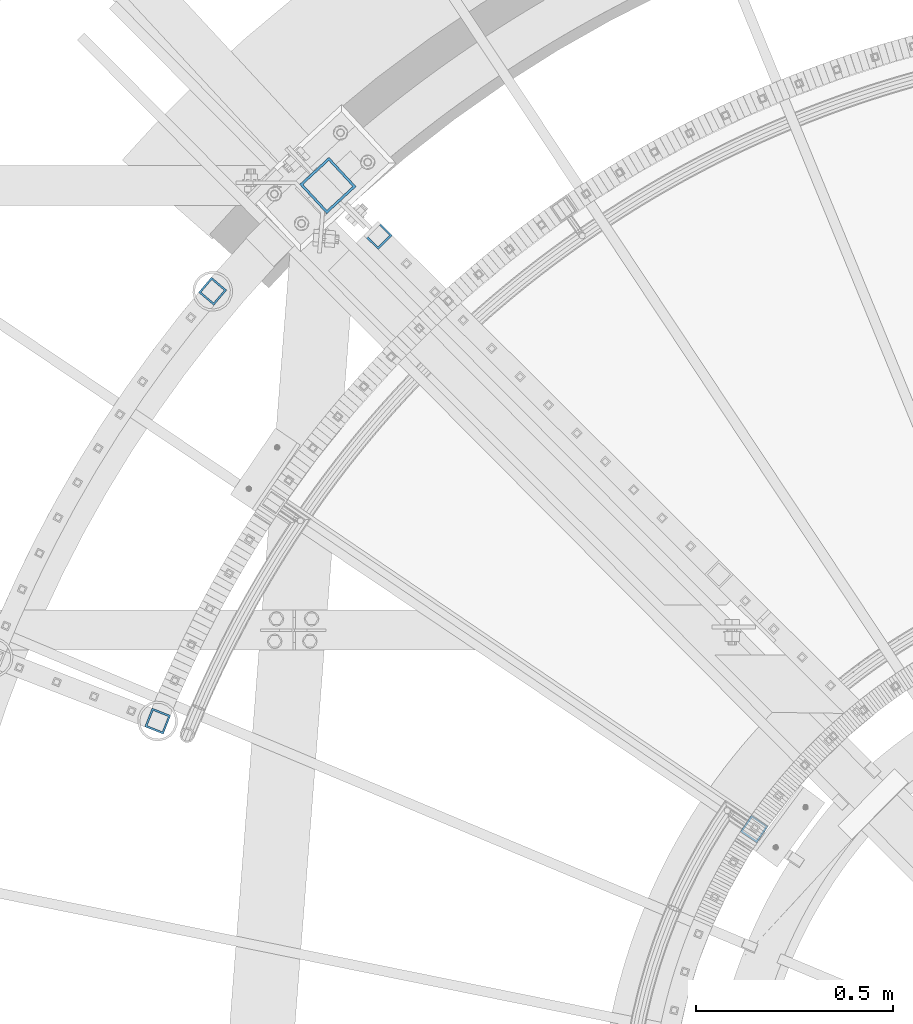
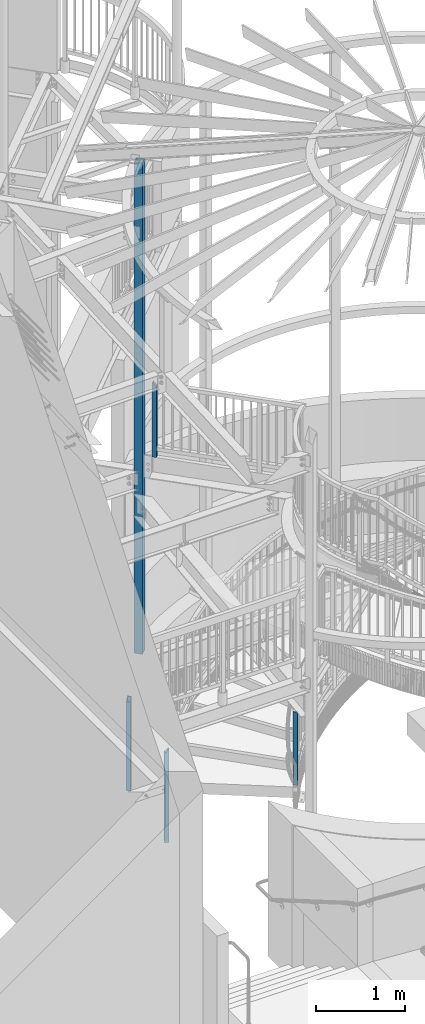
# One storey, part 134 of 975: 5 columns.
"""IFC2X3 building model written with IfcOpenShell, lengths in millimetres."""

import ifcopenshell
import ifcopenshell.guid

model = None  # the IFC model being written
_history = None  # IfcOwnerHistory: only IFC2X3 demands one
_inside = {}  # id of a spatial element -> (the spatial element, [elements in it])
_under = {}  # id of a project, library or spatial element -> (it, [spatial elements below it])
_declared = {}  # id of a project -> (the project, [libraries it declares])
_typed = {}  # id of a type object -> (the type object, [elements of that type])
_made_of = {}  # id of a material, layer set ... -> (it, [elements and type objects made of it])


def new_model(schema):
    """Start an empty IFC model of exactly this schema.

    Asked for "IFC4X3", IfcOpenShell would pick the latest addendum, in which some entities
    have other attributes; the version numbers below select the first issue.
    IFC2X3 requires an IfcOwnerHistory on every rooted entity: one is made here for all.
    """
    global model, _history
    if schema == "IFC4X3":
        model = ifcopenshell.file(schema_version=(4, 3, 0, 0))
    else:
        model = ifcopenshell.file(schema=schema)
    _inside.clear()
    _under.clear()
    _declared.clear()
    _typed.clear()
    _made_of.clear()
    _history = None
    if model.schema == "IFC2X3":
        org = make("IfcOrganization", Name="unknown")
        user = make(
            "IfcPersonAndOrganization",
            ThePerson=make("IfcPerson", FamilyName="unknown"),
            TheOrganization=org,
        )
        app = make(
            "IfcApplication",
            ApplicationDeveloper=org,
            Version="unknown",
            ApplicationFullName="unknown",
            ApplicationIdentifier="unknown",
        )
        _history = make(
            "IfcOwnerHistory",
            OwningUser=user,
            OwningApplication=app,
            ChangeAction="ADDED",
            CreationDate=0,
        )
    return model


def make(cls, **values):
    """One entity of the class cls with the attributes given. An attribute that is None is left unset."""
    return model.create_entity(
        cls, **{name: value for name, value in values.items() if value is not None}
    )


def rooted(cls, **values):
    """An entity with a GlobalId (a new one), such as an element, a storey or a relation."""
    return make(cls, GlobalId=ifcopenshell.guid.new(), OwnerHistory=_history, **values)


def si_unit(unit_type, name, prefix=None):
    """IfcSIUnit, for example si_unit("LENGTHUNIT", "METRE", prefix="MILLI")."""
    return make("IfcSIUnit", UnitType=unit_type, Prefix=prefix, Name=name)


def assignment(units):
    """IfcUnitAssignment: the units of a project."""
    return None if units is None else make("IfcUnitAssignment", Units=units)


def point(xyz):
    """IfcCartesianPoint."""
    return None if xyz is None else make("IfcCartesianPoint", Coordinates=xyz)


def direction(xyz):
    """IfcDirection."""
    return None if xyz is None else make("IfcDirection", DirectionRatios=xyz)


def frame(location, z_axis=None, x_axis=None):
    """IfcAxis2Placement3D, a coordinate frame: its origin and axes. An axis left out is left unset."""
    return make(
        "IfcAxis2Placement3D",
        Location=point(location),
        Axis=direction(z_axis),
        RefDirection=direction(x_axis),
    )


def origin_with_axes():
    """The frame at (0, 0, 0) with the z axis (0, 0, 1) and the x axis (1, 0, 0) written out."""
    return frame((0.0, 0.0, 0.0), z_axis=(0.0, 0.0, 1.0), x_axis=(1.0, 0.0, 0.0))


def place(relative_to, where):
    """IfcLocalPlacement: puts the frame where relative to a parent placement (None: the world)."""
    return make(
        "IfcLocalPlacement", PlacementRelTo=relative_to, RelativePlacement=where
    )


def context(
    kind, dimensions, precision=None, world=None, true_north=None, identifier=None
):
    """IfcGeometricRepresentationContext, for example the 3D "Model" context."""
    return make(
        "IfcGeometricRepresentationContext",
        ContextIdentifier=identifier,
        ContextType=kind,
        CoordinateSpaceDimension=dimensions,
        Precision=precision,
        WorldCoordinateSystem=world,
        TrueNorth=true_north,
    )


def subcontext(parent, identifier, kind, view, scale=None):
    """IfcGeometricRepresentationSubContext, for example "Body" below "Model"."""
    return make(
        "IfcGeometricRepresentationSubContext",
        ContextIdentifier=identifier,
        ContextType=kind,
        ParentContext=parent,
        TargetScale=scale,
        TargetView=view,
    )


def project(units=None, contexts=None):
    """IfcProject with its units and contexts."""
    return rooted(
        "IfcProject",
        Name="project",
        RepresentationContexts=contexts,
        UnitsInContext=assignment(units),
    )


def spatial(cls, under=None, at=None, **own):
    """A site, building, storey or space (cls), placed at a placement, below another one or the project."""
    s = rooted(cls, ObjectPlacement=at, **own)
    if under is not None:
        _under.setdefault(under.id(), (under, []))[1].append(s)
    return s


def faces_of(points, faces, orient=None, outer=None):
    """IfcFace entities. A face is a list of loops; a loop is a list of indices into points, from 0.

    orient and outer hold one flag for each loop. By default every Orientation is true, the
    first loop of a face is its IfcFaceOuterBound and the others are IfcFaceBound.
    """
    made = []
    for i, loops in enumerate(faces):
        bounds = []
        for j, loop in enumerate(loops):
            is_outer = j == 0 if outer is None else outer[i][j]
            bounds.append(
                make(
                    "IfcFaceOuterBound" if is_outer else "IfcFaceBound",
                    Bound=make("IfcPolyLoop", Polygon=[points[k] for k in loop]),
                    Orientation=True if orient is None else orient[i][j],
                )
            )
        made.append(make("IfcFace", Bounds=bounds))
    return made


def faceted_brep(points, faces, orient=None, outer=None, voids=None):
    """IfcFacetedBrep: a solid bounded by flat faces; with voids (closed shells), ...WithVoids."""
    shared = [point(p) for p in points]
    hull = make("IfcClosedShell", CfsFaces=faces_of(shared, faces, orient, outer))
    if voids is None:
        return make("IfcFacetedBrep", Outer=hull)
    return make(
        "IfcFacetedBrepWithVoids",
        Outer=hull,
        Voids=[
            make(cls, CfsFaces=faces_of(shared, fs, o, b)) for cls, fs, o, b in voids
        ],
    )


def shape(context_of_items, identifier, shape_type, items):
    """IfcShapeRepresentation: the items that make up one representation, for example the "Body"."""
    return make(
        "IfcShapeRepresentation",
        ContextOfItems=context_of_items,
        RepresentationIdentifier=identifier,
        RepresentationType=shape_type,
        Items=items,
    )


def material(Name=None, Category=None):
    """IfcMaterial."""
    return make("IfcMaterial", Name=Name, Category=Category)


def made_of(thing, what):
    """Note that an element or type object is made of a material, layer set ...; save() writes the relation."""
    if what is not None:
        _made_of.setdefault(what.id(), (what, []))[1].append(thing)
    return thing


def type_object(cls, material=None, **own):
    """A type object (cls), such as IfcWallType, which elements share."""
    return made_of(rooted(cls, **own), material)


def element(
    cls,
    number,
    at=None,
    inside=None,
    cuts=None,
    type_object=None,
    material=None,
    context=None,
    identifier="Body",
    shape_type=None,
    held_by="IfcProductDefinitionShape",
    body=None,
    shapes=None,
    **own,
):
    """One element of the class cls, such as IfcWall. Its Tag is "e" and its number.

    at: its placement. inside: the storey or other place that contains it. cuts: it is an
    opening in that element (IfcRelVoidsElement). A single representation is given by context,
    identifier, shape_type and body (its items); several are given by shapes. held_by: the class
    of the entity that holds the representations. save() writes the other relations.
    """
    e = rooted(cls, Tag="e%d" % number, ObjectPlacement=at, **own)
    if body is not None:
        shapes = [shape(context, identifier, shape_type, body)]
    if shapes is not None:
        e.Representation = make(held_by, Representations=shapes)
    if inside is not None:
        _inside.setdefault(inside.id(), (inside, []))[1].append(e)
    if cuts is not None:
        rooted(
            "IfcRelVoidsElement", RelatingBuildingElement=cuts, RelatedOpeningElement=e
        )
    if type_object is not None:
        _typed.setdefault(type_object.id(), (type_object, []))[1].append(e)
    return made_of(e, material)


def aggregate(whole, parts):
    """IfcRelAggregates: a whole, such as a stair, and the parts it consists of."""
    return rooted("IfcRelAggregates", RelatingObject=whole, RelatedObjects=parts)


def save(model, path):
    """Write the relations noted so far, then the file.

    IfcRelAggregates (storeys below a building ...), IfcRelContainedInSpatialStructure (elements
    in a storey), IfcRelDefinesByType, IfcRelAssociatesMaterial and IfcRelDeclares: one each for
    every whole, place, type object, material and project.
    """
    for whole, parts in _under.values():
        aggregate(whole, parts)
    for where, things in _inside.values():
        rooted(
            "IfcRelContainedInSpatialStructure",
            RelatedElements=things,
            RelatingStructure=where,
        )
    for kind, things in _typed.values():
        rooted("IfcRelDefinesByType", RelatedObjects=things, RelatingType=kind)
    for what, things in _made_of.values():
        rooted("IfcRelAssociatesMaterial", RelatedObjects=things, RelatingMaterial=what)
    for by, libraries in _declared.values():
        rooted("IfcRelDeclares", RelatingContext=by, RelatedDefinitions=libraries)
    model.write(path)


model = new_model("IFC2X3")

# Units and contexts
model_context = context("Model", 3, precision=1e-05, world=origin_with_axes())
body_context = subcontext(model_context, "Body", "Model", "MODEL_VIEW")
ifc_project = project(units=[si_unit("LENGTHUNIT", "METRE", prefix="MILLI"), si_unit("AREAUNIT", "SQUARE_METRE"), si_unit("VOLUMEUNIT", "CUBIC_METRE"), si_unit("MASSUNIT", "GRAM", prefix="KILO"), si_unit("TIMEUNIT", "SECOND"), si_unit("PLANEANGLEUNIT", "RADIAN"), si_unit("SOLIDANGLEUNIT", "STERADIAN"), si_unit("THERMODYNAMICTEMPERATUREUNIT", "DEGREE_CELSIUS"), si_unit("LUMINOUSINTENSITYUNIT", "LUMEN")], contexts=[model_context])

# Site, building, storey
site_placement = place(None, origin_with_axes())
site = spatial("IfcSite", under=ifc_project, at=site_placement, CompositionType="ELEMENT")
building_placement = place(site_placement, origin_with_axes())
building = spatial("IfcBuilding", under=site, at=building_placement, Name="Undefined", CompositionType="ELEMENT")
storey_placement = place(building_placement, origin_with_axes())
storey = spatial("IfcBuildingStorey", under=building, at=storey_placement, Name="Undefined", CompositionType="ELEMENT", Elevation=0.0)

# Columns
ifc_material = material()
column_type_1 = type_object("IfcColumnType", Name="HSS2X2X.188_TUBES", PredefinedType="NOTDEFINED")
column_1_placement = place(storey_placement, frame((32625.1078120215, 5693.2540656037, 4140.2), z_axis=(-0.708992011834517, 0.705216510835392, 0.0), x_axis=(0.0, 0.0, 1.0)))
element("IfcColumn", 1, at=column_1_placement, inside=storey, type_object=column_type_1, material=ifc_material, Name="HANDRAIL", ObjectType="HSS2X2X.188_TUBES", context=body_context, shape_type="Brep", body=[
    faceted_brep([(0.0, 20.6374999999753, -20.6375000000298), (0.0, -20.6375000000153, -20.6375000000153), (969.962499994079, -20.6375000000153, -20.6374999999753), (969.962499994073, 20.6375000000007, -20.637500000008), (0.0, -20.6374999999825, 20.6375000000335), (1011.23749999941, -20.637500000008, 20.6375000000116), (0.0, 20.6375000000116, 20.6375000000189), (1011.23749999941, 20.637500000008, 20.6374999999789), (0.0, 25.3999999999724, -25.4000000000342), (0.0, 25.400000000016, 25.4000000000196), (1016.00000000002, 25.4000000000087, 25.3999999999724), (965.200000000001, 25.4000000000124, -25.4000000000124), (0.0, -25.399999999976, 25.4000000000378), (1016.00000000003, -25.4000000000087, 25.4000000000124), (0.0, -25.400000000016, -25.4000000000196), (965.200000000001, -25.3999999998778, -25.4000000001033)], [[[0, 1, 2, 3]], [[1, 4, 5, 2]], [[4, 6, 7, 5]], [[6, 0, 3, 7]], [[8, 9, 10, 11]], [[9, 12, 13, 10]], [[12, 14, 15, 13]], [[14, 8, 11, 15]], [[13, 15, 11, 10], [5, 7, 3, 2]], [[14, 12, 9, 8], [6, 4, 1, 0]]]),
])
column_2_placement = place(storey_placement, frame((32066.5014628547, 4461.8210760123, -203.2), z_axis=(-0.92955143763421, 0.368692452854915, 0.0), x_axis=(0.0, 0.0, 1.0)))
element("IfcColumn", 2, at=column_2_placement, inside=storey, type_object=column_type_1, material=ifc_material, Name="HANDRAIL", ObjectType="HSS2X2X.188_TUBES", context=body_context, shape_type="Brep", body=[
    faceted_brep([(0.0, 20.6374999999753, -20.6375000000298), (0.0, -20.6375000000153, -20.6375000000153), (1264.87761763878, -20.6374999999953, -20.6375000000044), (1265.23750002613, 20.6375000000244, -20.6375000000262), (0.0, -20.6374999999825, 20.6375000000335), (1223.96250000265, -20.6375000000207, 20.6375000000371), (0.0, 20.6375000000116, 20.6375000000189), (1224.32238238999, 20.6374999999971, 20.6375000000153), (0.0, 25.3999999999724, -25.4000000000342), (0.0, 25.400000000016, 25.4000000000196), (1219.64293216898, 25.399999999996, 25.4000000000196), (1269.99998066427, 25.4000000005799, -25.4000000001936), (0.0, -25.399999999976, 25.4000000000378), (1219.19999934962, -25.399999999976, 25.4000000000378), (0.0, -25.400000000016, -25.4000000000196), (1269.5570678598, -25.399999999996, -25.4000000000087)], [[[0, 1, 2, 3]], [[1, 4, 5, 2]], [[4, 6, 7, 5]], [[6, 0, 3, 7]], [[8, 9, 10, 11]], [[9, 12, 13, 10]], [[12, 14, 15, 13]], [[14, 8, 11, 15]], [[13, 15, 11, 10], [5, 7, 3, 2]], [[14, 12, 9, 8], [6, 4, 1, 0]]]),
])
column_3_placement = place(storey_placement, frame((32205.7855764118, 5551.59857529668, -203.2), z_axis=(-0.762148808090179, 0.647401880076603, 0.0), x_axis=(0.0, 0.0, 1.0)))
element("IfcColumn", 3, at=column_3_placement, inside=storey, type_object=column_type_1, material=ifc_material, Name="HANDRAIL", ObjectType="HSS2X2X.188_TUBES", context=body_context, shape_type="Brep", body=[
    faceted_brep([(0.0, 20.6374999999753, -20.6375000000298), (0.0, -20.6375000000153, -20.6375000000153), (1223.96249999353, -20.6374999999753, -20.6375000000226), (1265.23750002613, 20.6375000000244, -20.6375000000262), (0.0, -20.6374999999825, 20.6375000000335), (1223.96250000265, -20.6375000000207, 20.6375000000371), (0.0, 20.6375000000116, 20.6375000000189), (1265.23749994241, 20.6374999999862, 20.6375000000153), (0.0, 25.3999999999724, -25.4000000000342), (0.0, 25.400000000016, 25.4000000000196), (1269.99997196214, 25.4000000000015, 25.4000000000135), (1269.99998066427, 25.4000000005799, -25.4000000001936), (0.0, -25.399999999976, 25.4000000000378), (1219.19999934962, -25.399999999976, 25.4000000000378), (0.0, -25.400000000016, -25.4000000000196), (1219.2, -25.399999999996, -25.4000000000378)], [[[0, 1, 2, 3]], [[1, 4, 5, 2]], [[4, 6, 7, 5]], [[6, 0, 3, 7]], [[8, 9, 10, 11]], [[9, 12, 13, 10]], [[12, 14, 15, 13]], [[14, 8, 11, 15]], [[13, 15, 11, 10], [5, 7, 3, 2]], [[14, 12, 9, 8], [6, 4, 1, 0]]]),
])
column_4_placement = place(storey_placement, frame((33578.7944109867, 4188.42710931981, 177.8), z_axis=(-0.827276728009954, 0.561794638006759, 0.0), x_axis=(0.0, 0.0, 1.0)))
element("IfcColumn", 4, at=column_4_placement, inside=storey, type_object=column_type_1, material=ifc_material, Name="HANDRAIL", ObjectType="HSS2X2X.188_TUBES", context=body_context, shape_type="Brep", body=[
    faceted_brep([(73.8216023003633, 20.6375000000298, -20.6375000000116), (46.7511421721683, -20.6375000000044, -20.6374999999971), (1047.85032143939, -20.6375000000444, -20.6374999999316), (1025.13806779634, 20.637499999968, -20.6374999999825), (46.7511421721192, -20.6375000000262, 20.6375000000116), (1047.85032143936, -20.6374999999607, 20.637499999968), (73.8216023003142, 20.6375000000044, 20.6374999999953), (1025.13806779632, 20.6375000000517, 20.6374999999171), (76.9451169305453, 25.4000000000306, -25.4000000000124), (76.9451169304848, 25.4000000000051, 25.3999999999942), (1022.51742314519, 25.4000000000669, 25.3999999998996), (1022.51742314523, 25.3999999999651, -25.3999999999724), (43.6276275419368, -25.4000000000306, 25.4000000000124), (1050.47096609048, -25.3999999999542, 25.3999999999651), (43.6276275419978, -25.4000000000015, -25.399999999996), (1050.47096609051, -25.400000000056, -25.3999999999141)], [[[0, 1, 2, 3]], [[1, 4, 5, 2]], [[4, 6, 7, 5]], [[6, 0, 3, 7]], [[8, 9, 10, 11]], [[9, 12, 13, 10]], [[12, 14, 15, 13]], [[14, 8, 11, 15]], [[13, 15, 11, 10], [5, 7, 3, 2]], [[14, 12, 9, 8], [6, 4, 1, 0]]]),
])
column_type_2 = type_object("IfcColumnType", Name="HSS4X4X1/4", PredefinedType="NOTDEFINED")
column_5_placement = place(storey_placement, frame((32497.8781598644, 5819.77763623706, 1409.7), z_axis=(0.733848438057782, 0.679313234053447, 0.0), x_axis=(0.0, 0.0, 1.0)))
element("IfcColumn", 5, at=column_5_placement, inside=storey, type_object=column_type_2, material=ifc_material, Name="COLUMN", ObjectType="HSS4X4X1/4", context=body_context, shape_type="Brep", body=[
    faceted_brep([(19.0499999999988, 44.4499999999998, -44.4500000000007), (19.0499999999988, -44.4499999999998, -44.4500000000007), (6753.225, -44.4499999999571, -44.4499999999389), (6753.225, 44.4500000000589, -44.4499999999462), (19.0499999999988, -44.4499999999998, 44.4500000000007), (6753.225, -44.4500000000626, 44.4499999999607), (19.0499999999988, 44.4499999999998, 44.4500000000007), (6753.225, 44.4499999999571, 44.4499999999498), (19.0499999999988, 50.8000000000002, -50.7999999999993), (19.0499999999988, 50.8000000000002, 50.7999999999993), (6753.225, 50.7999999999483, 50.7999999999447), (6753.225, 50.8000000000648, -50.7999999999447), (19.0499999999988, -50.8000000000002, 50.7999999999993), (6753.225, -50.800000000072, 50.799999999952), (19.0499999999988, -50.8000000000002, -50.7999999999993), (6753.225, -50.7999999999556, -50.7999999999302)], [[[0, 1, 2, 3]], [[1, 4, 5, 2]], [[4, 6, 7, 5]], [[6, 0, 3, 7]], [[8, 9, 10, 11]], [[9, 12, 13, 10]], [[12, 14, 15, 13]], [[14, 8, 11, 15]], [[13, 15, 11, 10], [5, 7, 3, 2]], [[14, 12, 9, 8], [6, 4, 1, 0]]]),
])

save(model, "model.ifc")
